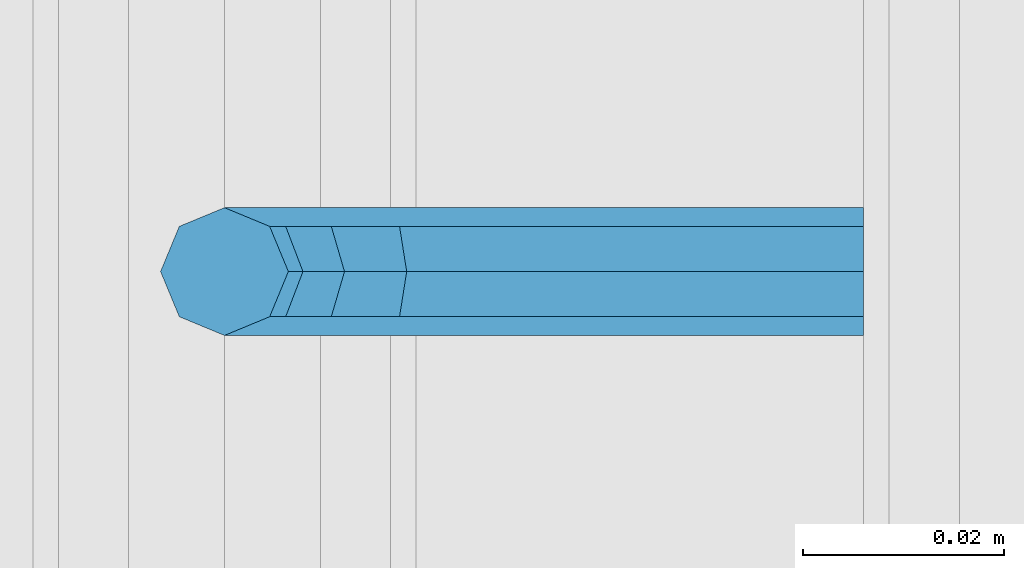
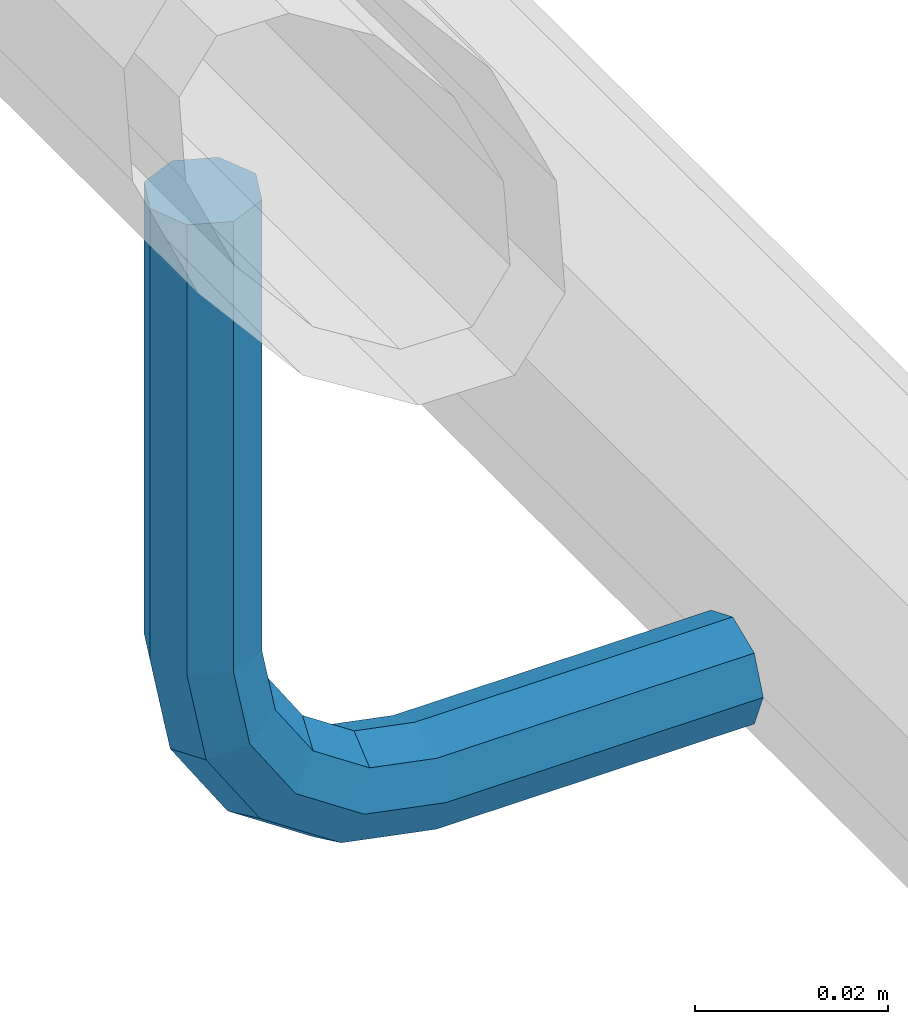
# One storey, part 1225 of 1876: 1 beam, 1 element without a shape of its own.
"""IFC2X3 building model written with IfcOpenShell, lengths in millimetres."""

from ifc_helpers import new_model, si_unit, frame, origin_with_axes, place, context, subcontext, project, spatial, faceted_brep, material, type_object, element, aggregate, save


model = new_model("IFC2X3")

# Units and contexts
model_context = context("Model", 3, precision=1e-05, world=origin_with_axes())
body_context = subcontext(model_context, "Body", "Model", "MODEL_VIEW")
ifc_project = project(units=[si_unit("LENGTHUNIT", "METRE", prefix="MILLI"), si_unit("AREAUNIT", "SQUARE_METRE"), si_unit("VOLUMEUNIT", "CUBIC_METRE"), si_unit("MASSUNIT", "GRAM", prefix="KILO"), si_unit("TIMEUNIT", "SECOND"), si_unit("PLANEANGLEUNIT", "RADIAN"), si_unit("SOLIDANGLEUNIT", "STERADIAN"), si_unit("THERMODYNAMICTEMPERATUREUNIT", "DEGREE_CELSIUS"), si_unit("LUMINOUSINTENSITYUNIT", "LUMEN")], contexts=[model_context])

# Site, building, storey
site_placement = place(None, origin_with_axes())
site = spatial("IfcSite", under=ifc_project, at=site_placement, CompositionType="ELEMENT")
building_placement = place(site_placement, origin_with_axes())
building = spatial("IfcBuilding", under=site, at=building_placement, Name="Undefined", CompositionType="ELEMENT")
storey_placement = place(building_placement, origin_with_axes())
storey = spatial("IfcBuildingStorey", under=building, at=storey_placement, Name="Undefined", CompositionType="ELEMENT", Elevation=0.0)

# Assembly, beam
assembly_placement = place(storey_placement, origin_with_axes())
assembly = element("IfcElementAssembly", 1, at=assembly_placement, inside=storey, Name="RAIL", AssemblyPlace="NOTDEFINED", PredefinedType="RIGID_FRAME")
ifc_material = material(Name="STEEL/A36")
beam_type = type_object("IfcBeamType", PredefinedType="NOTDEFINED")
beam_placement = place(assembly_placement, frame((9537.7001953125, -2743.20009321068, 939.800003052647), z_axis=(0.0, 1.0, 0.0), x_axis=(-1.0, 0.0, 0.0)))
beam = element("IfcBeam", 2, at=beam_placement, type_object=beam_type, material=ifc_material, Name="BRACKET", context=body_context, shape_type="Brep", body=[
    faceted_brep([(0.0, -6.35000000000036, 0.0), (0.0, -4.49012806053463, -4.49012806053452), (38.1000003814697, -4.49012806053463, -4.49012806053452), (38.1000003814697, -6.35000000000002, 0.0), (0.0, 0.0, -6.34999999999991), (38.1000003814697, 0.0, -6.34999999999991), (0.0, 4.49012806053463, -4.49012806053452), (38.1000003814697, 4.49012806053463, -4.49012806053452), (0.0, 6.35000000000036, 0.0), (38.1000003814697, 6.35000000000002, 0.0), (0.0, 4.49012806053463, 4.49012806053452), (38.1000003814697, 4.49012806053463, 4.49012806053452), (0.0, 0.0, 6.34999999999991), (38.1000003814697, 0.0, 6.34999999999991), (0.0, -4.49012806053463, 4.49012806053452), (38.1000003814697, -4.49012806053463, 4.49012806053452), (50.2501992130801, -3.93317518627066, 0.0), (49.5384570355254, -2.21487756830652, 4.49012806053452), (47.8201594175607, 1.93345984517589, 6.34999999999991), (46.1018617995978, 6.08179725865841, 4.49012806053452), (45.3901196220431, 7.80009487662255, 0.0), (46.1018617995978, 6.08179725865841, -4.49012806053452), (47.8201594175607, 1.93345984517589, -6.34999999999991), (49.5384570355254, -2.21487756830652, -4.49012806053452), (59.2355123538691, 4.26448764613235, -4.49012806053452), (60.5506404144035, 2.9493595855979, 0.0), (56.060512353868, 7.43948764613231, -6.34999999999991), (52.8855123538688, 10.6144876461323, -4.49012806053452), (51.5703842933344, 11.9296157066667, 0.0), (52.8855123538688, 10.6144876461323, 4.49012806053452), (56.060512353868, 7.43948764613231, 6.34999999999991), (59.2355123538691, 4.26448764613235, 4.49012806053452), (65.7148775683072, 13.9615429644757, -4.49012806053452), (67.4331751862719, 13.2498007869216, 0.0), (61.5665401548249, 15.6798405824397, -6.34999999999991), (57.4182027413426, 17.3981382004039, -4.49012806053452), (55.6999051233779, 18.1098803779579, 0.0), (57.4182027413426, 17.3981382004039, 4.49012806053452), (61.5665401548249, 15.6798405824397, 6.34999999999991), (65.7148775683072, 13.9615429644757, 4.49012806053452), (67.9901280605336, 25.3999996185304, -4.49012806053452), (69.8500000000004, 25.3999996185303, 0.0), (63.5, 25.3999996185303, -6.34999999999991), (59.0098719394646, 25.3999996185303, -4.49012806053452), (57.1499999999996, 25.3999996185303, 0.0), (59.0098719394646, 25.3999996185303, 4.49012806053452), (63.5, 25.3999996185303, 6.34999999999991), (67.9901280605336, 25.3999996185304, 4.49012806053452), (67.9901280605354, 82.5500030517578, -4.49012806053452), (69.8500000000004, 82.5500030517578, 0.0), (63.5, 82.5500030517578, -6.34999999999991), (59.0098719394646, 82.5500030517578, -4.49012806053452), (57.1499999999996, 82.5500030517578, 0.0), (59.0098719394646, 82.5500030517578, 4.49012806053452), (63.5, 82.5500030517578, 6.34999999999991), (67.9901280605354, 82.5500030517578, 4.49012806053452)], [[[0, 1, 2, 3]], [[1, 4, 5, 2]], [[4, 6, 7, 5]], [[6, 8, 9, 7]], [[8, 10, 11, 9]], [[10, 12, 13, 11]], [[12, 14, 15, 13]], [[14, 0, 3, 15]], [[14, 12, 10, 8, 6, 4, 1, 0]], [[15, 3, 16, 17]], [[13, 15, 17, 18]], [[11, 13, 18, 19]], [[9, 11, 19, 20]], [[7, 9, 20, 21]], [[5, 7, 21, 22]], [[2, 5, 22, 23]], [[3, 2, 23, 16]], [[23, 24, 25, 16]], [[22, 26, 24, 23]], [[21, 27, 26, 22]], [[20, 28, 27, 21]], [[19, 29, 28, 20]], [[18, 30, 29, 19]], [[17, 31, 30, 18]], [[16, 25, 31, 17]], [[24, 32, 33, 25]], [[26, 34, 32, 24]], [[27, 35, 34, 26]], [[28, 36, 35, 27]], [[29, 37, 36, 28]], [[30, 38, 37, 29]], [[31, 39, 38, 30]], [[25, 33, 39, 31]], [[32, 40, 41, 33]], [[34, 42, 40, 32]], [[35, 43, 42, 34]], [[36, 44, 43, 35]], [[37, 45, 44, 36]], [[38, 46, 45, 37]], [[39, 47, 46, 38]], [[33, 41, 47, 39]], [[41, 40, 48, 49]], [[40, 42, 50, 48]], [[42, 43, 51, 50]], [[43, 44, 52, 51]], [[44, 45, 53, 52]], [[45, 46, 54, 53]], [[46, 47, 55, 54]], [[47, 41, 49, 55]], [[50, 51, 52, 53, 54, 55, 49, 48]]]),
])
aggregate(assembly, [beam])

save(model, "model.ifc")
